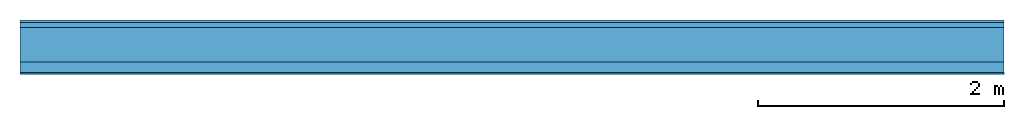
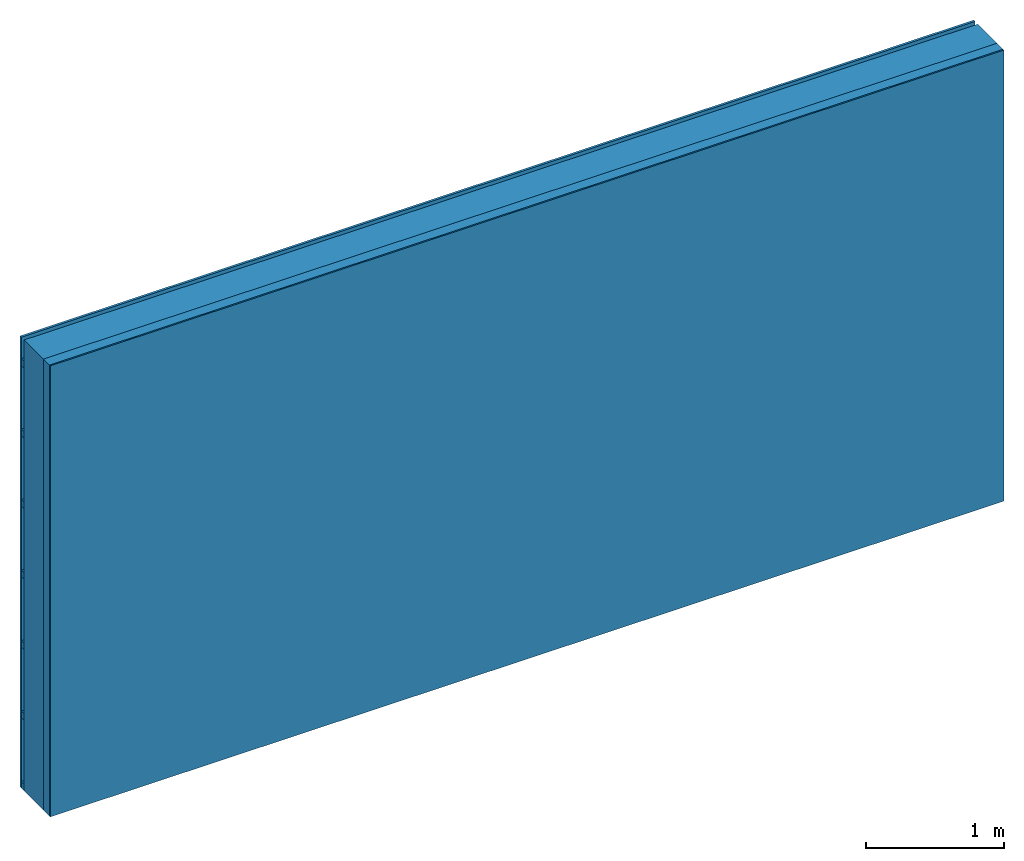
# One storey: 3 plates, 2 members, 1 element without a shape of its own.
"""IFC4 building model written with IfcOpenShell, lengths in metres."""

from ifc_helpers import new_model, si_unit, derived_unit, direction, frame, frame_2d, origin, origin_with_axes, place, context, project, spatial, rectangle, extrude, material, layer, layer_set, type_object, element, aggregate, save


model = new_model("IFC4")

# Units and contexts
plan_context = context("Plan", 3, precision=1e-05, world=origin(), true_north=direction((0.0, 1.0)))
model_context = context("Model", 3, precision=1e-05, world=origin(), true_north=direction((0.0, 1.0)))
ifc_project = project(units=[si_unit("LENGTHUNIT", "METRE"), derived_unit("SOUNDPRESSUREUNIT", [(si_unit("PRESSUREUNIT", "PASCAL", prefix="MICRO"), 0)]), si_unit("ENERGYUNIT", "JOULE", prefix="MEGA"), si_unit("MASSUNIT", "GRAM", prefix="KILO"), derived_unit("THERMALTRANSMITTANCEUNIT", [(si_unit("POWERUNIT", "WATT"), 1), (si_unit("AREAUNIT", "SQUARE_METRE"), -1), (si_unit("THERMODYNAMICTEMPERATUREUNIT", "KELVIN"), -1)]), derived_unit("AREADENSITYUNIT", [(si_unit("MASSUNIT", "GRAM", prefix="KILO"), 1), (si_unit("AREAUNIT", "SQUARE_METRE"), -1)]), derived_unit("USERDEFINED", [(si_unit("ENERGYUNIT", "JOULE", prefix="MEGA"), 1), (si_unit("AREAUNIT", "SQUARE_METRE"), -1)])], contexts=[plan_context, model_context])

# Site, building, storey
site = spatial("IfcSite", under=ifc_project)
building_placement = place(None, origin())
building = spatial("IfcBuilding", under=site, at=building_placement)
storey_placement = place(building_placement, origin())
storey = spatial("IfcBuildingStorey", under=building, at=storey_placement)

# Wall, members, plates
ifc_material_1 = material(Name="Wood cladding horizontal, closed")
ifc_layer_1 = layer(ifc_material_1, 0.02, Name="Cover 1st layer")
ifc_layer_2 = layer(None, 0.04, Name="Battens / profiles (ventilation)")
ifc_material_2 = material(Category="10.009")
ifc_layer_3 = layer(ifc_material_2, 0.28, Name="outside 1st layer")
ifc_material_3 = material(Name="of the art")
ifc_layer_4 = layer(ifc_material_3, 0.0, Name="Bond")
ifc_layer_5 = layer(None, 0.087, Name="Support")
ifc_layer_6 = layer(ifc_material_3, 0.0, Name="Bond")
ifc_material_4 = material(Name="Plasterboard type A", Category="03.008")
ifc_layer_7 = layer(ifc_material_4, 0.0125, Name="1st layer")
ifc_material_5 = material(Name="joints", Category="04.017")
ifc_layer_8 = layer(ifc_material_5, 0.0, Name="Surface")
ifc_layer_set = layer_set([ifc_layer_1, ifc_layer_2, ifc_layer_3, ifc_layer_4, ifc_layer_5, ifc_layer_6, ifc_layer_7, ifc_layer_8])
wall_type = type_object("IfcWallType", Name="D1012", PredefinedType="NOTDEFINED", material=ifc_layer_set)
wall_placement = place(None, frame((0.0, 0.0, 0.0), z_axis=(0.0, -1.0, 0.0), x_axis=(1.0, 0.0, 0.0)))
wall = element("IfcWall", 1, at=wall_placement, inside=storey, type_object=wall_type, material=ifc_layer_set, Name="Wall #1")
ifc_material_6 = material()
member_1_placement = place(wall_placement, origin())
member_1 = element("IfcMember", 2, at=member_1_placement, material=ifc_material_6, Name="Battens / profiles (ventilation)", context=plan_context, shape_type="SweptSolid", body=[
    extrude(rectangle(XDim=0.06, YDim=0.04, at=frame_2d((0.03, 0.02), x_axis=(1.0, 0.0))), frame((0.0, 0.0, 0.02), z_axis=(1.0, 0.0, 0.0), x_axis=(0.0, 1.0, 0.0)), (0.0, 0.0, 1.0), 8.0),
    extrude(rectangle(XDim=0.06, YDim=0.04, at=frame_2d((0.03, 0.02), x_axis=(1.0, 0.0))), frame((0.0, 0.625, 0.02), z_axis=(1.0, 0.0, 0.0), x_axis=(0.0, 1.0, 0.0)), (0.0, 0.0, 1.0), 8.0),
    extrude(rectangle(XDim=0.06, YDim=0.04, at=frame_2d((0.03, 0.02), x_axis=(1.0, 0.0))), frame((0.0, 1.25, 0.02), z_axis=(1.0, 0.0, 0.0), x_axis=(0.0, 1.0, 0.0)), (0.0, 0.0, 1.0), 8.0),
    extrude(rectangle(XDim=0.06, YDim=0.04, at=frame_2d((0.03, 0.02), x_axis=(1.0, 0.0))), frame((0.0, 1.875, 0.02), z_axis=(1.0, 0.0, 0.0), x_axis=(0.0, 1.0, 0.0)), (0.0, 0.0, 1.0), 8.0),
    extrude(rectangle(XDim=0.06, YDim=0.04, at=frame_2d((0.03, 0.02), x_axis=(1.0, 0.0))), frame((0.0, 2.5, 0.02), z_axis=(1.0, 0.0, 0.0), x_axis=(0.0, 1.0, 0.0)), (0.0, 0.0, 1.0), 8.0),
    extrude(rectangle(XDim=0.06, YDim=0.04, at=frame_2d((0.03, 0.02), x_axis=(1.0, 0.0))), frame((0.0, 3.125, 0.02), z_axis=(1.0, 0.0, 0.0), x_axis=(0.0, 1.0, 0.0)), (0.0, 0.0, 1.0), 8.0),
    extrude(rectangle(XDim=0.06, YDim=0.04, at=frame_2d((0.03, 0.02), x_axis=(1.0, 0.0))), frame((0.0, 3.75, 0.02), z_axis=(1.0, 0.0, 0.0), x_axis=(0.0, 1.0, 0.0)), (0.0, 0.0, 1.0), 8.0),
])
ifc_material_7 = material(Name="Solid timber panel")
member_2_placement = place(wall_placement, origin())
member_2 = element("IfcMember", 3, at=member_2_placement, material=ifc_material_7, Name="Support", context=plan_context, shape_type="SweptSolid", body=[
    extrude(rectangle(XDim=1.0, YDim=0.087, at=frame_2d((0.5, 0.0435), x_axis=(1.0, 0.0))), frame((0.0, 4.0, 0.34), z_axis=(0.0, -1.0, 0.0), x_axis=(1.0, 0.0, 0.0)), (0.0, 0.0, 1.0), 4.0),
    extrude(rectangle(XDim=1.0, YDim=0.087, at=frame_2d((0.5, 0.0435), x_axis=(1.0, 0.0))), frame((1.0, 4.0, 0.34), z_axis=(0.0, -1.0, 0.0), x_axis=(1.0, 0.0, 0.0)), (0.0, 0.0, 1.0), 4.0),
    extrude(rectangle(XDim=1.0, YDim=0.087, at=frame_2d((0.5, 0.0435), x_axis=(1.0, 0.0))), frame((2.0, 4.0, 0.34), z_axis=(0.0, -1.0, 0.0), x_axis=(1.0, 0.0, 0.0)), (0.0, 0.0, 1.0), 4.0),
    extrude(rectangle(XDim=1.0, YDim=0.087, at=frame_2d((0.5, 0.0435), x_axis=(1.0, 0.0))), frame((3.0, 4.0, 0.34), z_axis=(0.0, -1.0, 0.0), x_axis=(1.0, 0.0, 0.0)), (0.0, 0.0, 1.0), 4.0),
    extrude(rectangle(XDim=1.0, YDim=0.087, at=frame_2d((0.5, 0.0435), x_axis=(1.0, 0.0))), frame((4.0, 4.0, 0.34), z_axis=(0.0, -1.0, 0.0), x_axis=(1.0, 0.0, 0.0)), (0.0, 0.0, 1.0), 4.0),
    extrude(rectangle(XDim=1.0, YDim=0.087, at=frame_2d((0.5, 0.0435), x_axis=(1.0, 0.0))), frame((5.0, 4.0, 0.34), z_axis=(0.0, -1.0, 0.0), x_axis=(1.0, 0.0, 0.0)), (0.0, 0.0, 1.0), 4.0),
    extrude(rectangle(XDim=1.0, YDim=0.087, at=frame_2d((0.5, 0.0435), x_axis=(1.0, 0.0))), frame((6.0, 4.0, 0.34), z_axis=(0.0, -1.0, 0.0), x_axis=(1.0, 0.0, 0.0)), (0.0, 0.0, 1.0), 4.0),
    extrude(rectangle(XDim=1.0, YDim=0.087, at=frame_2d((0.5, 0.0435), x_axis=(1.0, 0.0))), frame((7.0, 4.0, 0.34), z_axis=(0.0, -1.0, 0.0), x_axis=(1.0, 0.0, 0.0)), (0.0, 0.0, 1.0), 4.0),
])
plate_1_placement = place(wall_placement, origin())
plate_1 = element("IfcPlate", 4, at=plate_1_placement, material=ifc_material_1, Name="Cover 1st layer", context=plan_context, shape_type="SweptSolid", body=[
    extrude(rectangle(XDim=8.0, YDim=4.0, at=frame_2d((4.0, 2.0), x_axis=(1.0, 0.0))), origin_with_axes(), (0.0, 0.0, 1.0), 0.02),
])
plate_2_placement = place(wall_placement, origin())
plate_2 = element("IfcPlate", 5, at=plate_2_placement, material=ifc_material_2, Name="outside 1st layer", context=plan_context, shape_type="SweptSolid", body=[
    extrude(rectangle(XDim=8.0, YDim=4.0, at=frame_2d((4.0, 2.0), x_axis=(1.0, 0.0))), frame((0.0, 0.0, 0.06), z_axis=(0.0, 0.0, 1.0), x_axis=(1.0, 0.0, 0.0)), (0.0, 0.0, 1.0), 0.28),
])
plate_3_placement = place(wall_placement, origin())
plate_3 = element("IfcPlate", 6, at=plate_3_placement, material=ifc_material_4, Name="1st layer", context=plan_context, shape_type="SweptSolid", body=[
    extrude(rectangle(XDim=8.0, YDim=4.0, at=frame_2d((4.0, 2.0), x_axis=(1.0, 0.0))), frame((0.0, 0.0, 0.427), z_axis=(0.0, 0.0, 1.0), x_axis=(1.0, 0.0, 0.0)), (0.0, 0.0, 1.0), 0.0125),
])
aggregate(wall, [plate_1, member_1, plate_2, member_2, plate_3])

save(model, "model.ifc")
